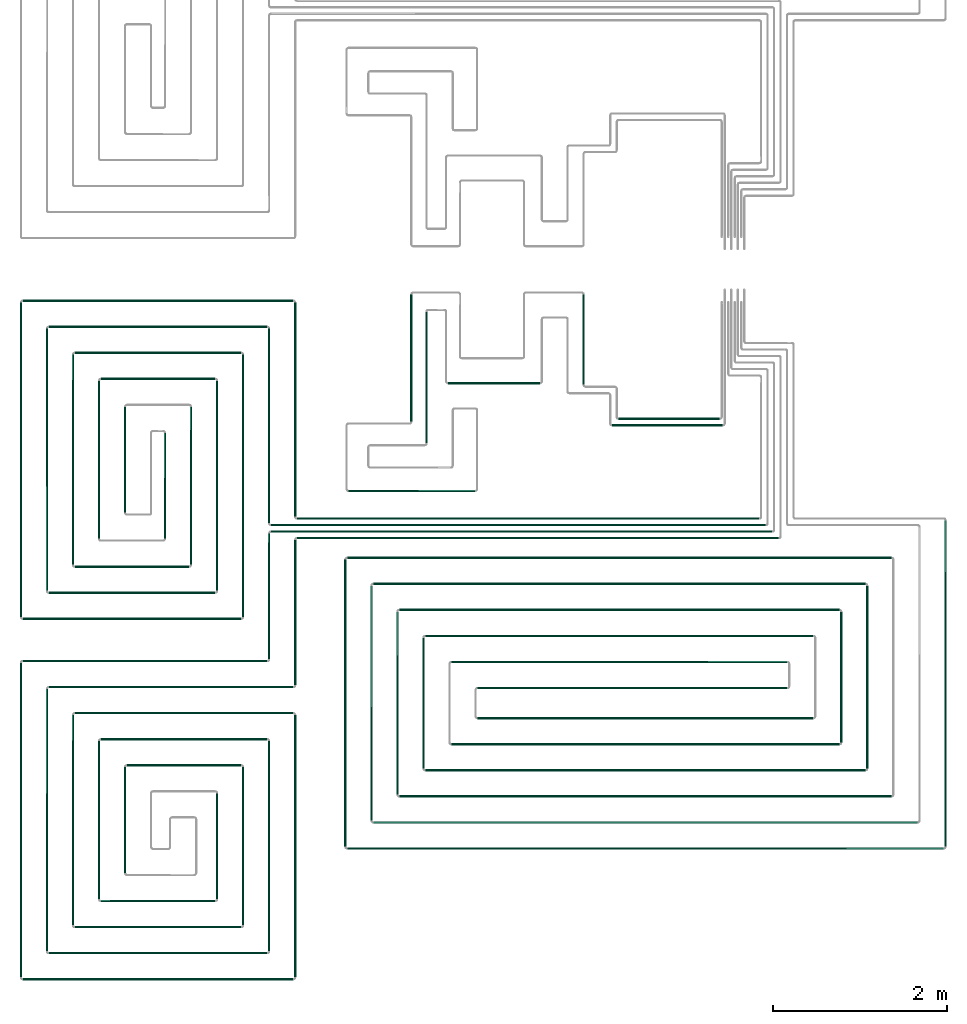
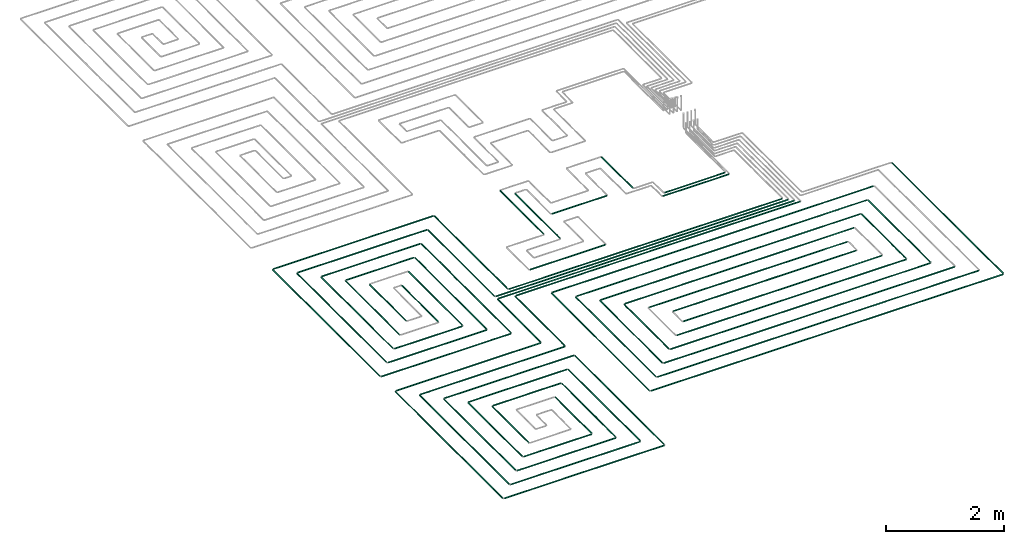
# One storey, part 1 of 12: 68 flow segments.
"""IFC2X3 building model written with IfcOpenShell, lengths in millimetres."""

from ifc_helpers import new_model, entity, si_unit, converted_unit, derived_unit, direction, frame, frame_2d, origin, origin_2d_with_axis, place, context, subcontext, project, spatial, circle, extrude, type_object, element, save


model = new_model("IFC2X3")

# Units and contexts
model_context = context("Model", 3, precision=0.01, world=origin(), true_north=direction((6.12303176911189e-17, 1.0)))
body_context = subcontext(model_context, "Body", "Model", "MODEL_VIEW")
ifc_project = project(units=[si_unit("LENGTHUNIT", "METRE", prefix="MILLI"), si_unit("AREAUNIT", "SQUARE_METRE"), si_unit("VOLUMEUNIT", "CUBIC_METRE"), converted_unit("PLANEANGLEUNIT", "DEGREE", entity("IfcRatioMeasure", 0.0174532925199433), si_unit("PLANEANGLEUNIT", "RADIAN"), dimensions=[0, 0, 0, 0, 0, 0, 0]), si_unit("MASSUNIT", "GRAM", prefix="KILO"), derived_unit("MASSDENSITYUNIT", [(si_unit("MASSUNIT", "GRAM", prefix="KILO"), 1), (si_unit("LENGTHUNIT", "METRE"), -3)]), si_unit("TIMEUNIT", "SECOND"), si_unit("FREQUENCYUNIT", "HERTZ"), si_unit("THERMODYNAMICTEMPERATUREUNIT", "DEGREE_CELSIUS"), derived_unit("THERMALTRANSMITTANCEUNIT", [(si_unit("MASSUNIT", "GRAM", prefix="KILO"), 1), (si_unit("THERMODYNAMICTEMPERATUREUNIT", "KELVIN"), -1), (si_unit("TIMEUNIT", "SECOND"), -3)]), derived_unit("VOLUMETRICFLOWRATEUNIT", [(si_unit("LENGTHUNIT", "METRE"), 3), (si_unit("TIMEUNIT", "SECOND"), -1)]), si_unit("ELECTRICCURRENTUNIT", "AMPERE"), si_unit("ELECTRICVOLTAGEUNIT", "VOLT"), si_unit("POWERUNIT", "WATT"), si_unit("FORCEUNIT", "NEWTON", prefix="KILO"), si_unit("ILLUMINANCEUNIT", "LUX"), si_unit("LUMINOUSFLUXUNIT", "LUMEN"), si_unit("LUMINOUSINTENSITYUNIT", "CANDELA"), derived_unit("USERDEFINED", [(si_unit("MASSUNIT", "GRAM", prefix="KILO"), -1), (si_unit("LENGTHUNIT", "METRE"), -2), (si_unit("TIMEUNIT", "SECOND"), 3), (si_unit("LUMINOUSFLUXUNIT", "LUMEN"), 1)]), derived_unit("LINEARVELOCITYUNIT", [(si_unit("LENGTHUNIT", "METRE"), 1), (si_unit("TIMEUNIT", "SECOND"), -1)]), si_unit("PRESSUREUNIT", "PASCAL"), derived_unit("USERDEFINED", [(si_unit("LENGTHUNIT", "METRE"), -2), (si_unit("MASSUNIT", "GRAM", prefix="KILO"), 1), (si_unit("TIMEUNIT", "SECOND"), -2)])], contexts=[model_context])

# Site, building, storey
site_placement = place(None, origin())
site = spatial("IfcSite", under=ifc_project, at=site_placement, CompositionType="ELEMENT")
building_placement = place(site_placement, origin())
building = spatial("IfcBuilding", under=site, at=building_placement, CompositionType="ELEMENT")
storey_placement = place(building_placement, frame((0.0, 0.0, 12000.0)))
storey = spatial("IfcBuildingStorey", under=building, at=storey_placement, Name="03 Level", CompositionType="ELEMENT", Elevation=12000.0)

# Flow segments
pipe_segment_type = type_object("IfcPipeSegmentType", PredefinedType="NOTDEFINED")
flow_segment_1_placement = place(storey_placement, frame((20884.4386293741, -71711.6450070283, -81.5952722359198)))
element("IfcFlowSegment", 1, at=flow_segment_1_placement, inside=storey, type_object=pipe_segment_type, context=body_context, shape_type="SweptSolid", body=[
    extrude(circle(Radius=10.0, at=frame_2d((-8.66293703438714e-12, 0.0), x_axis=(1.0, 0.0))), frame((0.0, 11.5952722359136, 11.5952722359158), z_axis=(1.0, 0.0, 0.0), x_axis=(0.0, 1.0, 0.0)), (0.0, 0.0, 1.0), 5324.24692007345),
])
flow_segment_2_placement = place(storey_placement, frame((20584.4386293741, -71786.6450070283, -81.5952722359161)))
element("IfcFlowSegment", 2, at=flow_segment_2_placement, inside=storey, type_object=pipe_segment_type, context=body_context, shape_type="SweptSolid", body=[
    extrude(circle(Radius=10.0, at=frame_2d((-8.66293703438714e-12, -2.16573425859679e-12), x_axis=(1.0, 0.0))), frame((0.0, 11.5952722359223, 11.595272235918), z_axis=(1.0, 0.0, 0.0), x_axis=(0.0, 1.0, 0.0)), (0.0, 0.0, 1.0), 5699.24692007345),
])
flow_segment_3_placement = place(storey_placement, frame((20584.4386293741, -71861.6450070283, -81.5952722359161)))
element("IfcFlowSegment", 3, at=flow_segment_3_placement, inside=storey, type_object=pipe_segment_type, context=body_context, shape_type="SweptSolid", body=[
    extrude(circle(Radius=10.0, at=frame_2d((-2.59888111031614e-11, -2.16573425859679e-12), x_axis=(1.0, 0.0))), frame((0.0, 11.5952722359396, 11.595272235918), z_axis=(1.0, 0.0, 0.0), x_axis=(0.0, 1.0, 0.0)), (0.0, 0.0, 1.0), 5774.24692007345),
])
flow_segment_4_placement = place(storey_placement, frame((20884.4386293741, -71936.6450070283, -81.5952722359161)))
element("IfcFlowSegment", 4, at=flow_segment_4_placement, inside=storey, type_object=pipe_segment_type, context=body_context, shape_type="SweptSolid", body=[
    extrude(circle(Radius=10.0, at=frame_2d((-1.73258740687743e-11, -2.16573425859679e-12), x_axis=(1.0, 0.0))), frame((0.0, 11.595272235931, 11.595272235918), z_axis=(1.0, 0.0, 0.0), x_axis=(0.0, 1.0, 0.0)), (0.0, 0.0, 1.0), 5549.24692007344),
])
flow_segment_5_placement = place(storey_placement, frame((20552.8433571382, -73321.2395851399, -81.5952722359198)))
element("IfcFlowSegment", 5, at=flow_segment_5_placement, inside=storey, type_object=pipe_segment_type, context=body_context, shape_type="SweptSolid", body=[
    extrude(circle(Radius=10.0, at=origin_2d_with_axis()), frame((11.595272235918, 0.0, 11.5952722359158), z_axis=(0.0, 1.0, 0.0), x_axis=(-1.0, 0.0, 0.0)), (0.0, 0.0, 1.0), 1451.18985034759),
])
flow_segment_6_placement = place(storey_placement, frame((20852.8433571382, -73621.2395851399, -81.5952722359198)))
element("IfcFlowSegment", 6, at=flow_segment_6_placement, inside=storey, type_object=pipe_segment_type, context=body_context, shape_type="SweptSolid", body=[
    extrude(circle(Radius=10.0, at=origin_2d_with_axis()), frame((11.5952722359223, 0.0, 11.5952722359158), z_axis=(0.0, 1.0, 0.0), x_axis=(-1.0, 0.0, 0.0)), (0.0, 0.0, 1.0), 1676.18985034759),
])
flow_segment_7_placement = place(storey_placement, frame((24586.730888343, -70562.9096240978, -81.595272235927)))
element("IfcFlowSegment", 7, at=flow_segment_7_placement, inside=storey, type_object=pipe_segment_type, context=body_context, shape_type="SweptSolid", body=[
    extrude(circle(Radius=10.0, at=origin_2d_with_axis()), frame((0.0, 11.5952722359136, 11.5952722359158), z_axis=(1.0, 0.0, 0.0), x_axis=(0.0, -1.0, 0.0)), (0.0, 0.0, 1.0), 1169.30608362779),
])
flow_segment_8_placement = place(storey_placement, frame((20852.8433571382, -71680.0497347924, -81.5952722359198)))
element("IfcFlowSegment", 8, at=flow_segment_8_placement, inside=storey, type_object=pipe_segment_type, context=body_context, shape_type="SweptSolid", body=[
    extrude(circle(Radius=10.0, at=frame_2d((-2.16573425859679e-11, 0.0), x_axis=(1.0, 0.0))), frame((11.5952722359396, 0.0, 11.5952722359158), z_axis=(0.0, 1.0, 0.0), x_axis=(-1.0, 0.0, 0.0)), (0.0, 0.0, 1.0), 2468.81014965244),
])
flow_segment_9_placement = place(storey_placement, frame((20552.8433571382, -71755.0497347924, -81.5952722359198)))
element("IfcFlowSegment", 9, at=flow_segment_9_placement, inside=storey, type_object=pipe_segment_type, context=body_context, shape_type="SweptSolid", body=[
    extrude(circle(Radius=10.0, at=origin_2d_with_axis()), frame((11.5952722359223, 0.0, 11.5952722359158), z_axis=(0.0, 1.0, 0.0), x_axis=(1.0, 0.0, 0.0)), (0.0, 0.0, 1.0), 2243.81014965244),
])
flow_segment_10_placement = place(storey_placement, frame((17725.6253473195, -69202.8348573759, -81.5952722359198)))
element("IfcFlowSegment", 10, at=flow_segment_10_placement, inside=storey, type_object=pipe_segment_type, context=body_context, shape_type="SweptSolid", body=[
    extrude(circle(Radius=10.0, at=frame_2d((-1.73258740687743e-11, 0.0), x_axis=(1.0, 0.0))), frame((0.0, 11.595272235931, 11.5952722359158), z_axis=(1.0, 0.0, 0.0), x_axis=(0.0, 1.0, 0.0)), (0.0, 0.0, 1.0), 3118.81328205467),
])
flow_segment_11_placement = place(storey_placement, frame((18025.6253473195, -69502.8348573758, -81.5952722359198)))
element("IfcFlowSegment", 11, at=flow_segment_11_placement, inside=storey, type_object=pipe_segment_type, context=body_context, shape_type="SweptSolid", body=[
    extrude(circle(Radius=10.0, at=frame_2d((-1.73258740687743e-11, 0.0), x_axis=(1.0, 0.0))), frame((0.0, 11.595272235931, 11.5952722359158), z_axis=(1.0, 0.0, 0.0), x_axis=(0.0, 1.0, 0.0)), (0.0, 0.0, 1.0), 2518.81328205467),
])
flow_segment_12_placement = place(storey_placement, frame((17994.0300750835, -72534.5978364231, -81.5952722359198)))
element("IfcFlowSegment", 12, at=flow_segment_12_placement, inside=storey, type_object=pipe_segment_type, context=body_context, shape_type="SweptSolid", body=[
    extrude(circle(Radius=10.0, at=frame_2d((-2.38230768445646e-11, 0.0), x_axis=(1.0, 0.0))), frame((11.5952722359396, 0.0, 11.5952722359158), z_axis=(0.0, 1.0, 0.0), x_axis=(-1.0, 0.0, 0.0)), (0.0, 0.0, 1.0), 3023.35825128324),
])
flow_segment_13_placement = place(storey_placement, frame((17694.0300750835, -72834.5978364231, -81.5952722359216)))
element("IfcFlowSegment", 13, at=flow_segment_13_placement, inside=storey, type_object=pipe_segment_type, context=body_context, shape_type="SweptSolid", body=[
    extrude(circle(Radius=10.0, at=frame_2d((-2.16573425859679e-11, 0.0), x_axis=(1.0, 0.0))), frame((11.5952722359374, 0.0, 11.5952722359158), z_axis=(0.0, 1.0, 0.0), x_axis=(-1.0, 0.0, 0.0)), (0.0, 0.0, 1.0), 3623.35825128323),
])
flow_segment_14_placement = place(storey_placement, frame((18025.6253473194, -72566.1931086591, -81.5952722359198)))
element("IfcFlowSegment", 14, at=flow_segment_14_placement, inside=storey, type_object=pipe_segment_type, context=body_context, shape_type="SweptSolid", body=[
    extrude(circle(Radius=10.0, at=frame_2d((-8.66293703438714e-12, 0.0), x_axis=(1.0, 0.0))), frame((0.0, 11.5952722359223, 11.5952722359158), z_axis=(1.0, 0.0, 0.0), x_axis=(0.0, 1.0, 0.0)), (0.0, 0.0, 1.0), 1918.81328205468),
])
flow_segment_15_placement = place(storey_placement, frame((17725.6253473194, -72866.1931086591, -81.5952722359198)))
element("IfcFlowSegment", 15, at=flow_segment_15_placement, inside=storey, type_object=pipe_segment_type, context=body_context, shape_type="SweptSolid", body=[
    extrude(circle(Radius=10.0, at=frame_2d((-8.66293703438714e-12, 0.0), x_axis=(1.0, 0.0))), frame((0.0, 11.595272235931, 11.5952722359158), z_axis=(1.0, 0.0, 0.0), x_axis=(0.0, 1.0, 0.0)), (0.0, 0.0, 1.0), 2518.81328205467),
])
flow_segment_16_placement = place(storey_placement, frame((20252.8433571382, -72834.5978364231, -81.5952722359216)))
element("IfcFlowSegment", 16, at=flow_segment_16_placement, inside=storey, type_object=pipe_segment_type, context=body_context, shape_type="SweptSolid", body=[
    extrude(circle(Radius=10.0, at=frame_2d((-2.59888111031614e-11, 0.0), x_axis=(1.0, 0.0))), frame((11.5952722359396, 0.0, 11.5952722359158), z_axis=(0.0, 1.0, 0.0), x_axis=(-1.0, 0.0, 0.0)), (0.0, 0.0, 1.0), 3023.35825128323),
])
flow_segment_17_placement = place(storey_placement, frame((19952.8433571382, -72534.5978364231, -81.5952722359198)))
element("IfcFlowSegment", 17, at=flow_segment_17_placement, inside=storey, type_object=pipe_segment_type, context=body_context, shape_type="SweptSolid", body=[
    extrude(circle(Radius=10.0, at=origin_2d_with_axis()), frame((11.5952722359223, 0.0, 11.5952722359158), z_axis=(0.0, 1.0, 0.0), x_axis=(1.0, 0.0, 0.0)), (0.0, 0.0, 1.0), 2423.35825128325),
])
flow_segment_18_placement = place(storey_placement, frame((18325.6253473194, -69802.8348573758, -81.5952722359234)))
element("IfcFlowSegment", 18, at=flow_segment_18_placement, inside=storey, type_object=pipe_segment_type, context=body_context, shape_type="SweptSolid", body=[
    extrude(circle(Radius=10.0, at=origin_2d_with_axis()), frame((0.0, 11.5952722359396, 11.5952722359158), z_axis=(1.0, 0.0, 0.0), x_axis=(0.0, -1.0, 0.0)), (0.0, 0.0, 1.0), 1918.8132820547),
])
flow_segment_19_placement = place(storey_placement, frame((18625.6253473194, -70102.8348573758, -81.5952722359216)))
element("IfcFlowSegment", 19, at=flow_segment_19_placement, inside=storey, type_object=pipe_segment_type, context=body_context, shape_type="SweptSolid", body=[
    extrude(circle(Radius=10.0, at=frame_2d((-8.66293703438714e-12, 0.0), x_axis=(1.0, 0.0))), frame((0.0, 11.5952722359223, 11.5952722359158), z_axis=(1.0, 0.0, 0.0), x_axis=(0.0, 1.0, 0.0)), (0.0, 0.0, 1.0), 1318.8132820547),
])
flow_segment_20_placement = place(storey_placement, frame((18594.0300750835, -71934.5978364232, -81.5952722359216)))
element("IfcFlowSegment", 20, at=flow_segment_20_placement, inside=storey, type_object=pipe_segment_type, context=body_context, shape_type="SweptSolid", body=[
    extrude(circle(Radius=10.0, at=frame_2d((-1.94916083273711e-11, 0.0), x_axis=(1.0, 0.0))), frame((11.5952722359353, 0.0, 11.5952722359158), z_axis=(0.0, 1.0, 0.0), x_axis=(-1.0, 0.0, 0.0)), (0.0, 0.0, 1.0), 1823.35825128327),
])
flow_segment_21_placement = place(storey_placement, frame((18294.0300750835, -72234.5978364231, -81.5952722359216)))
element("IfcFlowSegment", 21, at=flow_segment_21_placement, inside=storey, type_object=pipe_segment_type, context=body_context, shape_type="SweptSolid", body=[
    extrude(circle(Radius=10.0, at=frame_2d((-1.94916083273711e-11, 0.0), x_axis=(1.0, 0.0))), frame((11.5952722359353, 0.0, 11.5952722359158), z_axis=(0.0, 1.0, 0.0), x_axis=(-1.0, 0.0, 0.0)), (0.0, 0.0, 1.0), 2423.35825128326),
])
flow_segment_22_placement = place(storey_placement, frame((18325.6253473194, -72266.1931086591, -81.5952722359234)))
element("IfcFlowSegment", 22, at=flow_segment_22_placement, inside=storey, type_object=pipe_segment_type, context=body_context, shape_type="SweptSolid", body=[
    extrude(circle(Radius=10.0, at=frame_2d((-8.66293703438714e-12, 0.0), x_axis=(1.0, 0.0))), frame((0.0, 11.5952722359223, 11.5952722359158), z_axis=(1.0, 0.0, 0.0), x_axis=(0.0, 1.0, 0.0)), (0.0, 0.0, 1.0), 1318.81328205471),
])
flow_segment_23_placement = place(storey_placement, frame((19652.8433571382, -72234.5978364232, -81.5952722359234)))
element("IfcFlowSegment", 23, at=flow_segment_23_placement, inside=storey, type_object=pipe_segment_type, context=body_context, shape_type="SweptSolid", body=[
    extrude(circle(Radius=10.0, at=frame_2d((-1.29944055515807e-11, 0.0), x_axis=(1.0, 0.0))), frame((11.595272235931, 0.0, 11.5952722359158), z_axis=(0.0, 1.0, 0.0), x_axis=(-1.0, 0.0, 0.0)), (0.0, 0.0, 1.0), 1823.35825128327),
])
flow_segment_24_placement = place(storey_placement, frame((19352.8433571382, -71934.5978364232, -81.5952722359234)))
element("IfcFlowSegment", 24, at=flow_segment_24_placement, inside=storey, type_object=pipe_segment_type, context=body_context, shape_type="SweptSolid", body=[
    extrude(circle(Radius=10.0, at=frame_2d((-8.66293703438714e-12, 0.0), x_axis=(1.0, 0.0))), frame((11.5952722359245, 0.0, 11.5952722359158), z_axis=(0.0, 1.0, 0.0), x_axis=(-1.0, 0.0, 0.0)), (0.0, 0.0, 1.0), 1223.35825128328),
])
flow_segment_25_placement = place(storey_placement, frame((18894.0300750835, -71634.5978364232, -81.5952722359252)))
element("IfcFlowSegment", 25, at=flow_segment_25_placement, inside=storey, type_object=pipe_segment_type, context=body_context, shape_type="SweptSolid", body=[
    extrude(circle(Radius=10.0, at=frame_2d((-1.51601398101775e-11, -2.16573425859679e-12), x_axis=(1.0, 0.0))), frame((11.595272235931, 0.0, 11.595272235918), z_axis=(0.0, 1.0, 0.0), x_axis=(-1.0, 0.0, 0.0)), (0.0, 0.0, 1.0), 1223.35825128332),
])
flow_segment_26_placement = place(storey_placement, frame((20852.8433571382, -76984.5978364232, -81.5952722359198)))
element("IfcFlowSegment", 26, at=flow_segment_26_placement, inside=storey, type_object=pipe_segment_type, context=body_context, shape_type="SweptSolid", body=[
    extrude(circle(Radius=10.0, at=frame_2d((-2.59888111031614e-11, 0.0), x_axis=(1.0, 0.0))), frame((11.5952722359353, 0.0, 11.5952722359158), z_axis=(0.0, 1.0, 0.0), x_axis=(-1.0, 0.0, 0.0)), (0.0, 0.0, 1.0), 3023.35825128325),
])
flow_segment_27_placement = place(storey_placement, frame((20552.8433571382, -76684.5978364232, -81.5952722359198)))
element("IfcFlowSegment", 27, at=flow_segment_27_placement, inside=storey, type_object=pipe_segment_type, context=body_context, shape_type="SweptSolid", body=[
    extrude(circle(Radius=10.0, at=origin_2d_with_axis()), frame((11.595272235918, 0.0, 11.5952722359158), z_axis=(0.0, 1.0, 0.0), x_axis=(1.0, 0.0, 0.0)), (0.0, 0.0, 1.0), 2423.35825128326),
])
flow_segment_28_placement = place(storey_placement, frame((17994.0300750835, -76684.5978364232, -81.5952722359216)))
element("IfcFlowSegment", 28, at=flow_segment_28_placement, inside=storey, type_object=pipe_segment_type, context=body_context, shape_type="SweptSolid", body=[
    extrude(circle(Radius=10.0, at=frame_2d((-2.81545453617582e-11, 0.0), x_axis=(1.0, 0.0))), frame((11.5952722359439, 0.0, 11.5952722359158), z_axis=(0.0, 1.0, 0.0), x_axis=(-1.0, 0.0, 0.0)), (0.0, 0.0, 1.0), 3023.35825128327),
])
flow_segment_29_placement = place(storey_placement, frame((17694.0300750835, -76984.5978364231, -81.5952722359234)))
element("IfcFlowSegment", 29, at=flow_segment_29_placement, inside=storey, type_object=pipe_segment_type, context=body_context, shape_type="SweptSolid", body=[
    extrude(circle(Radius=10.0, at=frame_2d((-2.81545453617582e-11, 0.0), x_axis=(1.0, 0.0))), frame((11.5952722359418, 0.0, 11.5952722359158), z_axis=(0.0, 1.0, 0.0), x_axis=(-1.0, 0.0, 0.0)), (0.0, 0.0, 1.0), 3623.35825128325),
])
flow_segment_30_placement = place(storey_placement, frame((20252.8433571382, -76384.5978364232, -81.5952722359234)))
element("IfcFlowSegment", 30, at=flow_segment_30_placement, inside=storey, type_object=pipe_segment_type, context=body_context, shape_type="SweptSolid", body=[
    extrude(circle(Radius=10.0, at=frame_2d((-2.16573425859679e-11, 0.0), x_axis=(1.0, 0.0))), frame((11.5952722359396, 0.0, 11.5952722359158), z_axis=(0.0, 1.0, 0.0), x_axis=(-1.0, 0.0, 0.0)), (0.0, 0.0, 1.0), 1823.35825128329),
])
flow_segment_31_placement = place(storey_placement, frame((19952.8433571382, -76084.5978364232, -81.5952722359198)))
element("IfcFlowSegment", 31, at=flow_segment_31_placement, inside=storey, type_object=pipe_segment_type, context=body_context, shape_type="SweptSolid", body=[
    extrude(circle(Radius=10.0, at=origin_2d_with_axis()), frame((11.595272235918, 0.0, 11.5952722359158), z_axis=(0.0, 1.0, 0.0), x_axis=(1.0, 0.0, 0.0)), (0.0, 0.0, 1.0), 1223.35825128325),
])
flow_segment_32_placement = place(storey_placement, frame((18594.0300750835, -76084.5978364232, -81.595272235927)))
element("IfcFlowSegment", 32, at=flow_segment_32_placement, inside=storey, type_object=pipe_segment_type, context=body_context, shape_type="SweptSolid", body=[
    extrude(circle(Radius=10.0, at=origin_2d_with_axis()), frame((11.5952722359158, 0.0, 11.5952722359158), z_axis=(0.0, 1.0, 0.0), x_axis=(1.0, 0.0, 0.0)), (0.0, 0.0, 1.0), 1823.35825128331),
])
flow_segment_33_placement = place(storey_placement, frame((18294.0300750835, -76384.5978364232, -81.595272235927)))
element("IfcFlowSegment", 33, at=flow_segment_33_placement, inside=storey, type_object=pipe_segment_type, context=body_context, shape_type="SweptSolid", body=[
    extrude(circle(Radius=10.0, at=origin_2d_with_axis()), frame((11.5952722359158, 0.0, 11.5952722359158), z_axis=(0.0, 1.0, 0.0), x_axis=(1.0, 0.0, 0.0)), (0.0, 0.0, 1.0), 2423.35825128329),
])
flow_segment_34_placement = place(storey_placement, frame((18894.0300750835, -75784.5978364232, -81.5952722359252)))
element("IfcFlowSegment", 34, at=flow_segment_34_placement, inside=storey, type_object=pipe_segment_type, context=body_context, shape_type="SweptSolid", body=[
    extrude(circle(Radius=10.0, at=frame_2d((-2.16573425859679e-11, -2.16573425859679e-12), x_axis=(1.0, 0.0))), frame((11.5952722359353, 0.0, 11.595272235918), z_axis=(0.0, 1.0, 0.0), x_axis=(-1.0, 0.0, 0.0)), (0.0, 0.0, 1.0), 1223.35825128335),
])
flow_segment_35_placement = place(storey_placement, frame((17725.6253473195, -73352.8348573759, -81.5952722359161)))
element("IfcFlowSegment", 35, at=flow_segment_35_placement, inside=storey, type_object=pipe_segment_type, context=body_context, shape_type="SweptSolid", body=[
    extrude(circle(Radius=10.0, at=frame_2d((-3.46517481375486e-11, -2.16573425859679e-12), x_axis=(1.0, 0.0))), frame((0.0, 11.5952722359483, 11.595272235918), z_axis=(1.0, 0.0, 0.0), x_axis=(0.0, 1.0, 0.0)), (0.0, 0.0, 1.0), 2818.81328205464),
])
flow_segment_36_placement = place(storey_placement, frame((18025.6253473194, -73652.8348573759, -81.5952722359198)))
element("IfcFlowSegment", 36, at=flow_segment_36_placement, inside=storey, type_object=pipe_segment_type, context=body_context, shape_type="SweptSolid", body=[
    extrude(circle(Radius=10.0, at=frame_2d((-3.46517481375486e-11, 0.0), x_axis=(1.0, 0.0))), frame((0.0, 11.5952722359483, 11.5952722359158), z_axis=(1.0, 0.0, 0.0), x_axis=(0.0, 1.0, 0.0)), (0.0, 0.0, 1.0), 2818.81328205464),
])
flow_segment_37_placement = place(storey_placement, frame((18025.6253473194, -76716.1931086591, -81.5952722359198)))
element("IfcFlowSegment", 37, at=flow_segment_37_placement, inside=storey, type_object=pipe_segment_type, context=body_context, shape_type="SweptSolid", body=[
    extrude(circle(Radius=10.0, at=frame_2d((-8.66293703438714e-12, 0.0), x_axis=(1.0, 0.0))), frame((0.0, 11.5952722359136, 11.5952722359158), z_axis=(1.0, 0.0, 0.0), x_axis=(0.0, 1.0, 0.0)), (0.0, 0.0, 1.0), 2518.8132820547),
])
flow_segment_38_placement = place(storey_placement, frame((17725.6253473194, -77016.1931086591, -81.5952722359161)))
element("IfcFlowSegment", 38, at=flow_segment_38_placement, inside=storey, type_object=pipe_segment_type, context=body_context, shape_type="SweptSolid", body=[
    extrude(circle(Radius=10.0, at=frame_2d((-8.66293703438714e-12, -2.16573425859679e-12), x_axis=(1.0, 0.0))), frame((0.0, 11.595272235931, 11.595272235918), z_axis=(1.0, 0.0, 0.0), x_axis=(0.0, 1.0, 0.0)), (0.0, 0.0, 1.0), 3118.81328205468),
])
flow_segment_39_placement = place(storey_placement, frame((18325.6253473194, -73952.8348573758, -81.5952722359198)))
element("IfcFlowSegment", 39, at=flow_segment_39_placement, inside=storey, type_object=pipe_segment_type, context=body_context, shape_type="SweptSolid", body=[
    extrude(circle(Radius=10.0, at=frame_2d((-1.73258740687743e-11, 0.0), x_axis=(1.0, 0.0))), frame((0.0, 11.595272235931, 11.5952722359158), z_axis=(1.0, 0.0, 0.0), x_axis=(0.0, 1.0, 0.0)), (0.0, 0.0, 1.0), 2518.8132820547),
])
flow_segment_40_placement = place(storey_placement, frame((18625.6253473194, -74252.8348573758, -81.5952722359198)))
element("IfcFlowSegment", 40, at=flow_segment_40_placement, inside=storey, type_object=pipe_segment_type, context=body_context, shape_type="SweptSolid", body=[
    extrude(circle(Radius=10.0, at=frame_2d((-1.73258740687743e-11, 0.0), x_axis=(1.0, 0.0))), frame((0.0, 11.595272235931, 11.5952722359158), z_axis=(1.0, 0.0, 0.0), x_axis=(0.0, 1.0, 0.0)), (0.0, 0.0, 1.0), 1918.8132820547),
])
flow_segment_41_placement = place(storey_placement, frame((18625.6253473194, -76116.1931086591, -81.5952722359216)))
element("IfcFlowSegment", 41, at=flow_segment_41_placement, inside=storey, type_object=pipe_segment_type, context=body_context, shape_type="SweptSolid", body=[
    extrude(circle(Radius=10.0, at=origin_2d_with_axis()), frame((0.0, 11.5952722359136, 11.5952722359158), z_axis=(1.0, 0.0, 0.0), x_axis=(0.0, 1.0, 0.0)), (0.0, 0.0, 1.0), 1318.81328205473),
])
flow_segment_42_placement = place(storey_placement, frame((18325.6253473194, -76416.1931086591, -81.5952722359216)))
element("IfcFlowSegment", 42, at=flow_segment_42_placement, inside=storey, type_object=pipe_segment_type, context=body_context, shape_type="SweptSolid", body=[
    extrude(circle(Radius=10.0, at=frame_2d((-8.66293703438714e-12, 0.0), x_axis=(1.0, 0.0))), frame((0.0, 11.5952722359223, 11.5952722359158), z_axis=(1.0, 0.0, 0.0), x_axis=(0.0, 1.0, 0.0)), (0.0, 0.0, 1.0), 1918.81328205471),
])
flow_segment_43_placement = place(storey_placement, frame((18925.6253473194, -74552.8348573758, -81.5952722359234)))
element("IfcFlowSegment", 43, at=flow_segment_43_placement, inside=storey, type_object=pipe_segment_type, context=body_context, shape_type="SweptSolid", body=[
    extrude(circle(Radius=10.0, at=frame_2d((-8.66293703438714e-12, 0.0), x_axis=(1.0, 0.0))), frame((0.0, 11.5952722359223, 11.5952722359158), z_axis=(1.0, 0.0, 0.0), x_axis=(0.0, 1.0, 0.0)), (0.0, 0.0, 1.0), 1318.81328205473),
])
flow_segment_44_placement = place(storey_placement, frame((28341.5018091839, -75479.8436457932, -81.5952722359161)))
element("IfcFlowSegment", 44, at=flow_segment_44_placement, inside=storey, type_object=pipe_segment_type, context=body_context, shape_type="SweptSolid", body=[
    extrude(circle(Radius=10.0, at=origin_2d_with_axis()), frame((11.595272235918, 0.0, 11.5952722359158), z_axis=(0.0, 1.0, 0.0), x_axis=(1.0, 0.0, 0.0)), (0.0, 0.0, 1.0), 3759.79391100087),
])
flow_segment_45_placement = place(storey_placement, frame((27441.5018091839, -74579.8436457933, -81.5952722359161)))
element("IfcFlowSegment", 45, at=flow_segment_45_placement, inside=storey, type_object=pipe_segment_type, context=body_context, shape_type="SweptSolid", body=[
    extrude(circle(Radius=10.0, at=frame_2d((-2.16573425859679e-11, -2.16573425859679e-12), x_axis=(1.0, 0.0))), frame((11.5952722359396, 0.0, 11.595272235918), z_axis=(0.0, 1.0, 0.0), x_axis=(-1.0, 0.0, 0.0)), (0.0, 0.0, 1.0), 2107.85893213088),
])
flow_segment_46_placement = place(storey_placement, frame((21730.6562350407, -75179.8436457932, -81.595272235927)))
element("IfcFlowSegment", 46, at=flow_segment_46_placement, inside=storey, type_object=pipe_segment_type, context=body_context, shape_type="SweptSolid", body=[
    extrude(circle(Radius=10.0, at=frame_2d((-3.46517481375486e-11, 0.0), x_axis=(1.0, 0.0))), frame((11.5952722359526, 0.0, 11.5952722359158), z_axis=(0.0, 1.0, 0.0), x_axis=(-1.0, 0.0, 0.0)), (0.0, 0.0, 1.0), 2707.85893213097),
])
flow_segment_47_placement = place(storey_placement, frame((21430.6562350407, -75479.8436457932, -81.595272235927)))
element("IfcFlowSegment", 47, at=flow_segment_47_placement, inside=storey, type_object=pipe_segment_type, context=body_context, shape_type="SweptSolid", body=[
    extrude(circle(Radius=10.0, at=frame_2d((-2.59888111031614e-11, 0.0), x_axis=(1.0, 0.0))), frame((11.5952722359483, 0.0, 11.5952722359158), z_axis=(0.0, 1.0, 0.0), x_axis=(-1.0, 0.0, 0.0)), (0.0, 0.0, 1.0), 3307.85893213096),
])
flow_segment_48_placement = place(storey_placement, frame((22330.6562350407, -74579.8436457932, -81.5952722359325)))
element("IfcFlowSegment", 48, at=flow_segment_48_placement, inside=storey, type_object=pipe_segment_type, context=body_context, shape_type="SweptSolid", body=[
    extrude(circle(Radius=10.0, at=frame_2d((-2.59888111031614e-11, 0.0), x_axis=(1.0, 0.0))), frame((11.5952722359353, 0.0, 11.5952722359158), z_axis=(0.0, 1.0, 0.0), x_axis=(-1.0, 0.0, 0.0)), (0.0, 0.0, 1.0), 1507.858932131),
])
flow_segment_49_placement = place(storey_placement, frame((22030.6562350407, -74879.8436457932, -81.5952722359325)))
element("IfcFlowSegment", 49, at=flow_segment_49_placement, inside=storey, type_object=pipe_segment_type, context=body_context, shape_type="SweptSolid", body=[
    extrude(circle(Radius=10.0, at=frame_2d((-2.16573425859679e-11, 0.0), x_axis=(1.0, 0.0))), frame((11.5952722359396, 0.0, 11.5952722359158), z_axis=(0.0, 1.0, 0.0), x_axis=(-1.0, 0.0, 0.0)), (0.0, 0.0, 1.0), 2107.85893213099),
])
flow_segment_50_placement = place(storey_placement, frame((21762.2515072766, -75211.4389180292, -81.595272235927)))
element("IfcFlowSegment", 50, at=flow_segment_50_placement, inside=storey, type_object=pipe_segment_type, context=body_context, shape_type="SweptSolid", body=[
    extrude(circle(Radius=10.0, at=origin_2d_with_axis()), frame((0.0, 11.5952722359483, 11.5952722359158), z_axis=(1.0, 0.0, 0.0), x_axis=(0.0, -1.0, 0.0)), (0.0, 0.0, 1.0), 6270.84557414324),
])
flow_segment_51_placement = place(storey_placement, frame((21462.2515072766, -75511.4389180292, -81.5952722359161)))
element("IfcFlowSegment", 51, at=flow_segment_51_placement, inside=storey, type_object=pipe_segment_type, context=body_context, shape_type="SweptSolid", body=[
    extrude(circle(Radius=10.0, at=frame_2d((-2.59888111031614e-11, -2.16573425859679e-12), x_axis=(1.0, 0.0))), frame((0.0, 11.5952722359396, 11.595272235918), z_axis=(1.0, 0.0, 0.0), x_axis=(0.0, 1.0, 0.0)), (0.0, 0.0, 1.0), 6870.84557414322),
])
flow_segment_52_placement = place(storey_placement, frame((22362.2515072766, -74611.4389180292, -81.5952722359216)))
element("IfcFlowSegment", 52, at=flow_segment_52_placement, inside=storey, type_object=pipe_segment_type, context=body_context, shape_type="SweptSolid", body=[
    extrude(circle(Radius=10.0, at=frame_2d((-8.66293703438714e-12, 0.0), x_axis=(1.0, 0.0))), frame((0.0, 11.5952722359223, 11.5952722359158), z_axis=(1.0, 0.0, 0.0), x_axis=(0.0, 1.0, 0.0)), (0.0, 0.0, 1.0), 5070.84557414327),
])
flow_segment_53_placement = place(storey_placement, frame((22062.2515072766, -74911.4389180292, -81.5952722359289)))
element("IfcFlowSegment", 53, at=flow_segment_53_placement, inside=storey, type_object=pipe_segment_type, context=body_context, shape_type="SweptSolid", body=[
    extrude(circle(Radius=10.0, at=frame_2d((0.0, -2.16573425859679e-12), x_axis=(1.0, 0.0))), frame((0.0, 11.5952722359656, 11.5952722359136), z_axis=(1.0, 0.0, 0.0), x_axis=(0.0, -1.0, 0.0)), (0.0, 0.0, 1.0), 5670.84557414326),
])
flow_segment_54_placement = place(storey_placement, frame((21462.2515072766, -72163.5799858983, -81.595272235927)))
element("IfcFlowSegment", 54, at=flow_segment_54_placement, inside=storey, type_object=pipe_segment_type, context=body_context, shape_type="SweptSolid", body=[
    extrude(circle(Radius=10.0, at=frame_2d((-7.79664333094843e-11, 0.0), x_axis=(1.0, 0.0))), frame((0.0, 11.5952722359916, 11.5952722359158), z_axis=(1.0, 0.0, 0.0), x_axis=(0.0, 1.0, 0.0)), (0.0, 0.0, 1.0), 6270.84557414324),
])
flow_segment_55_placement = place(storey_placement, frame((21762.2515072766, -72463.5799858983, -81.5952722359161)))
element("IfcFlowSegment", 55, at=flow_segment_55_placement, inside=storey, type_object=pipe_segment_type, context=body_context, shape_type="SweptSolid", body=[
    extrude(circle(Radius=10.0, at=frame_2d((-6.064055924071e-11, -2.16573425859679e-12), x_axis=(1.0, 0.0))), frame((0.0, 11.5952722359829, 11.595272235918), z_axis=(1.0, 0.0, 0.0), x_axis=(0.0, 1.0, 0.0)), (0.0, 0.0, 1.0), 5670.84557414323),
])
flow_segment_56_placement = place(storey_placement, frame((22062.2515072766, -72763.5799858982, -81.5952722359252)))
element("IfcFlowSegment", 56, at=flow_segment_56_placement, inside=storey, type_object=pipe_segment_type, context=body_context, shape_type="SweptSolid", body=[
    extrude(circle(Radius=10.0, at=frame_2d((-5.19776222063229e-11, -2.16573425859679e-12), x_axis=(1.0, 0.0))), frame((0.0, 11.5952722359656, 11.595272235918), z_axis=(1.0, 0.0, 0.0), x_axis=(0.0, 1.0, 0.0)), (0.0, 0.0, 1.0), 5070.84557414326),
])
flow_segment_57_placement = place(storey_placement, frame((22362.2515072766, -73063.5799858982, -81.5952722359216)))
element("IfcFlowSegment", 57, at=flow_segment_57_placement, inside=storey, type_object=pipe_segment_type, context=body_context, shape_type="SweptSolid", body=[
    extrude(circle(Radius=10.0, at=frame_2d((-4.33146851719357e-11, 0.0), x_axis=(1.0, 0.0))), frame((0.0, 11.5952722359569, 11.5952722359158), z_axis=(1.0, 0.0, 0.0), x_axis=(0.0, 1.0, 0.0)), (0.0, 0.0, 1.0), 4470.84557414325),
])
flow_segment_58_placement = place(storey_placement, frame((27141.5018091839, -74279.8436457933, -81.5952722359216)))
element("IfcFlowSegment", 58, at=flow_segment_58_placement, inside=storey, type_object=pipe_segment_type, context=body_context, shape_type="SweptSolid", body=[
    extrude(circle(Radius=10.0, at=frame_2d((0.0, -2.16573425859679e-12), x_axis=(1.0, 0.0))), frame((11.595272235918, 0.0, 11.5952722359136), z_axis=(0.0, 1.0, 0.0), x_axis=(1.0, 0.0, 0.0)), (0.0, 0.0, 1.0), 1507.85893213094),
])
flow_segment_59_placement = place(storey_placement, frame((22962.2515072765, -74011.4389180292, -81.5952722359398)))
element("IfcFlowSegment", 59, at=flow_segment_59_placement, inside=storey, type_object=pipe_segment_type, context=body_context, shape_type="SweptSolid", body=[
    extrude(circle(Radius=10.0, at=origin_2d_with_axis()), frame((0.0, 11.595272235931, 11.5952722359158), z_axis=(1.0, 0.0, 0.0), x_axis=(0.0, -1.0, 0.0)), (0.0, 0.0, 1.0), 3870.84557414329),
])
flow_segment_60_placement = place(storey_placement, frame((22662.2515072766, -74311.4389180292, -81.5952722359325)))
element("IfcFlowSegment", 60, at=flow_segment_60_placement, inside=storey, type_object=pipe_segment_type, context=body_context, shape_type="SweptSolid", body=[
    extrude(circle(Radius=10.0, at=origin_2d_with_axis()), frame((0.0, 11.5952722359483, 11.5952722359158), z_axis=(1.0, 0.0, 0.0), x_axis=(0.0, -1.0, 0.0)), (0.0, 0.0, 1.0), 4470.84557414328),
])
flow_segment_61_placement = place(storey_placement, frame((22662.2515072766, -73363.5799858982, -81.595272235927)))
element("IfcFlowSegment", 61, at=flow_segment_61_placement, inside=storey, type_object=pipe_segment_type, context=body_context, shape_type="SweptSolid", body=[
    extrude(circle(Radius=10.0, at=frame_2d((-4.33146851719357e-11, 0.0), x_axis=(1.0, 0.0))), frame((0.0, 11.5952722359569, 11.5952722359158), z_axis=(1.0, 0.0, 0.0), x_axis=(0.0, 1.0, 0.0)), (0.0, 0.0, 1.0), 3870.84557414328),
])
flow_segment_62_placement = place(storey_placement, frame((22962.2515072766, -73663.5799858983, -81.595272235927)))
element("IfcFlowSegment", 62, at=flow_segment_62_placement, inside=storey, type_object=pipe_segment_type, context=body_context, shape_type="SweptSolid", body=[
    extrude(circle(Radius=10.0, at=frame_2d((-5.19776222063229e-11, 0.0), x_axis=(1.0, 0.0))), frame((0.0, 11.5952722359656, 11.5952722359158), z_axis=(1.0, 0.0, 0.0), x_axis=(0.0, 1.0, 0.0)), (0.0, 0.0, 1.0), 3570.8455741433),
])
flow_segment_63_placement = place(storey_placement, frame((24174.4137837032, -70162.4616421941, -81.5952722359289)))
element("IfcFlowSegment", 63, at=flow_segment_63_placement, inside=storey, type_object=pipe_segment_type, context=body_context, shape_type="SweptSolid", body=[
    extrude(circle(Radius=10.0, at=frame_2d((-3.46517481375486e-11, 0.0), x_axis=(1.0, 0.0))), frame((11.5952722359483, 0.0, 11.5952722359158), z_axis=(0.0, 1.0, 0.0), x_axis=(-1.0, 0.0, 0.0)), (0.0, 0.0, 1.0), 1044.42186360162),
])
flow_segment_64_placement = place(storey_placement, frame((21476.9829033853, -71393.9202306541, -81.5952722359289)))
element("IfcFlowSegment", 64, at=flow_segment_64_placement, inside=storey, type_object=pipe_segment_type, context=body_context, shape_type="SweptSolid", body=[
    extrude(circle(Radius=10.0, at=origin_2d_with_axis()), frame((0.0, 11.5952722359136, 11.5952722359158), z_axis=(1.0, 0.0, 0.0), x_axis=(0.0, 1.0, 0.0)), (0.0, 0.0, 1.0), 1461.77751147482),
])
flow_segment_65_placement = place(storey_placement, frame((22190.153709968, -70586.2395851399, -81.5952722359289)))
element("IfcFlowSegment", 65, at=flow_segment_65_placement, inside=storey, type_object=pipe_segment_type, context=body_context, shape_type="SweptSolid", body=[
    extrude(circle(Radius=10.0, at=frame_2d((-1.29944055515807e-11, 0.0), x_axis=(1.0, 0.0))), frame((11.595272235931, 0.0, 11.5952722359158), z_axis=(0.0, 1.0, 0.0), x_axis=(-1.0, 0.0, 0.0)), (0.0, 0.0, 1.0), 1468.19980654745),
])
flow_segment_66_placement = place(storey_placement, frame((22365.153709968, -70836.2395851399, -81.5952722359234)))
element("IfcFlowSegment", 66, at=flow_segment_66_placement, inside=storey, type_object=pipe_segment_type, context=body_context, shape_type="SweptSolid", body=[
    extrude(circle(Radius=10.0, at=frame_2d((-1.29944055515807e-11, 0.0), x_axis=(1.0, 0.0))), frame((11.595272235931, 0.0, 11.5952722359158), z_axis=(0.0, 1.0, 0.0), x_axis=(-1.0, 0.0, 0.0)), (0.0, 0.0, 1.0), 1518.19980654744),
])
flow_segment_67_placement = place(storey_placement, frame((24511.730888343, -70637.9096240978, -81.5952722359252)))
element("IfcFlowSegment", 67, at=flow_segment_67_placement, inside=storey, type_object=pipe_segment_type, context=body_context, shape_type="SweptSolid", body=[
    extrude(circle(Radius=10.0, at=origin_2d_with_axis()), frame((0.0, 11.5952722359136, 11.5952722359158), z_axis=(1.0, 0.0, 0.0), x_axis=(0.0, -1.0, 0.0)), (0.0, 0.0, 1.0), 1279.3060836278),
])
flow_segment_68_placement = place(storey_placement, frame((22622.1485075651, -70152.8348573759, -81.5952722359343)))
element("IfcFlowSegment", 68, at=flow_segment_68_placement, inside=storey, type_object=pipe_segment_type, context=body_context, shape_type="SweptSolid", body=[
    extrude(circle(Radius=10.0, at=frame_2d((-1.73258740687743e-11, -2.16573425859679e-12), x_axis=(1.0, 0.0))), frame((0.0, 11.595272235931, 11.595272235918), z_axis=(1.0, 0.0, 0.0), x_axis=(0.0, 1.0, 0.0)), (0.0, 0.0, 1.0), 1062.80764523384),
])

save(model, "model.ifc")
